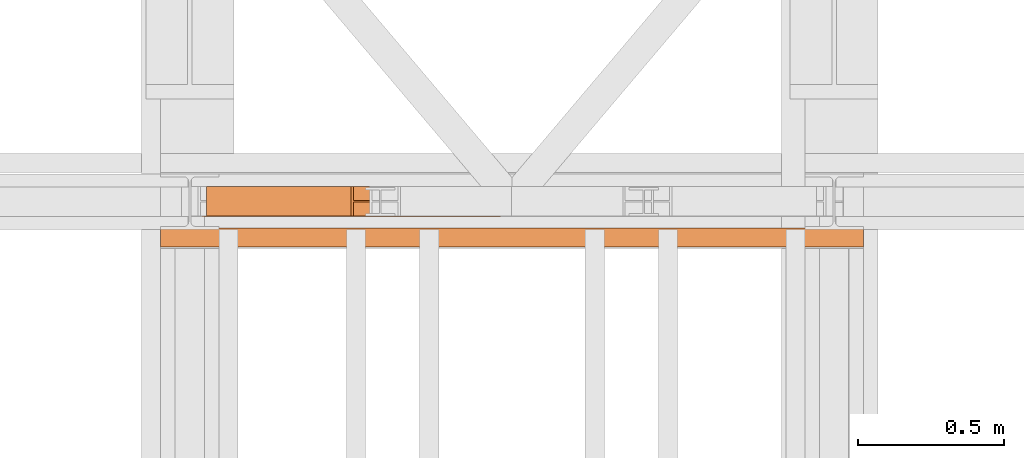
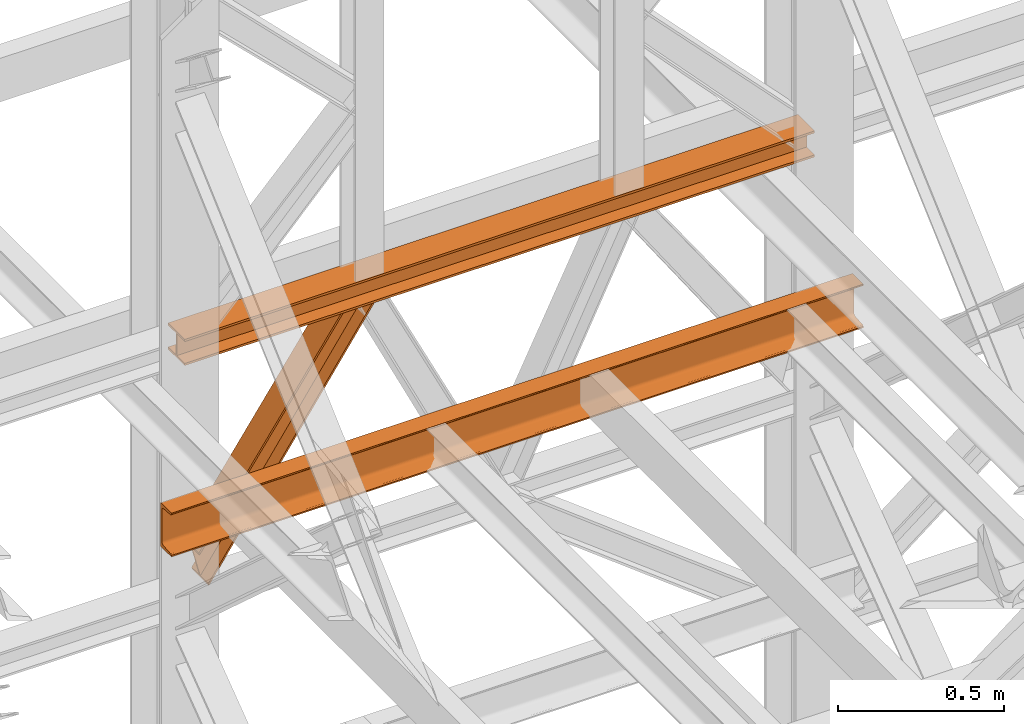
# One storey, part 163 of 208: 3 proxies.
"""IFC2X3 building model written with IfcOpenShell, lengths in millimetres."""

from ifc_helpers import new_model, entity, si_unit, converted_unit, frame, origin, origin_with_axes, place, context, subcontext, project, spatial, faceted_brep, element, save


model = new_model("IFC2X3")

# Units and contexts
model_context = context("Model", 3, precision=1e-05, world=origin())
plan_context = context("Plan", 3, precision=1e-05, world=origin())
body_context = subcontext(model_context, "Body", "Model", "MODEL_VIEW")
ifc_project = project(units=[si_unit("LENGTHUNIT", "METRE", prefix="MILLI"), converted_unit("PLANEANGLEUNIT", "DEGREE", entity("IfcPlaneAngleMeasure", 0.0174532925199433), si_unit("PLANEANGLEUNIT", "RADIAN"), dimensions=[0, 0, 0, 0, 0, 0, 0]), si_unit("AREAUNIT", "SQUARE_METRE"), si_unit("VOLUMEUNIT", "CUBIC_METRE")], contexts=[model_context, plan_context])

# Building, storey
building_placement = place(None, origin())
building = spatial("IfcBuilding", under=ifc_project, at=building_placement, CompositionType="COMPLEX")
storey_placement = place(building_placement, origin_with_axes())
storey = spatial("IfcBuildingStorey", under=building, at=storey_placement, Name="Geschoss", CompositionType="ELEMENT")

# Proxies
proxy_1_placement = place(storey_placement, frame((3350.592727804951, -13810.57439404318, 8872.310477686953), z_axis=(0.0, 0.0, 1.0), x_axis=(1.0, 0.0, 0.0)))
element("IfcBuildingElementProxy", 1, at=proxy_1_placement, inside=storey, context=body_context, shape_type="Brep", body=[
    faceted_brep([(2.129900098894723, 0.01000000000021828, 123.6259631817866), (0.01000000000021828, 0.01000000000021828, 131.7181462696044), (493.3676242930887, 0.01000000000021828, 837.8052355353921), (501.726157097236, 0.01000000000021828, 837.8052355353921), (0.01000000000021828, 0.01000000000021828, 131.7181462696044), (0.01000000000021828, 100.0100000000002, 131.7181462696044), (493.3676242930919, 100.0100000000002, 837.8052355353921), (493.3676242930887, 0.01000000000021828, 837.8052355353921), (0.01000000000021828, 100.0100000000002, 131.7181462696044), (2.129900098894723, 100.0100000000002, 123.6259631817866), (501.726157097236, 100.0100000000002, 837.8052355353921), (493.3676242930919, 100.0100000000002, 837.8052355353921), (2.129900098894723, 100.0100000000002, 123.6259631817866), (2.129900098894723, 52.51000000000022, 123.6259631817866), (501.7261570972382, 52.51000000000022, 837.8052355353921), (501.726157097236, 100.0100000000002, 837.8052355353921), (2.129900098894723, 52.51000000000022, 123.6259631817866), (32.3939208726315, 52.51000000000022, 8.100709325468415), (601.3553964383027, 52.51000000000022, 837.8052355353921), (501.7261570972382, 52.51000000000022, 837.8052355353921), (32.3939208726315, 52.51000000000022, 8.100709325468415), (32.39392087263059, 100.0100000000002, 8.100709325472053), (601.3553964382991, 100.0100000000002, 837.8052355353921), (601.3553964383027, 52.51000000000022, 837.8052355353921), (32.39392087263059, 100.0100000000002, 8.100709325472053), (34.51343489165902, 100.0100000000002, 0.01000000000021828), (609.6918638003699, 100.0100000000002, 837.8052355353921), (601.3553964382991, 100.0100000000002, 837.8052355353921), (34.51343489165902, 100.0100000000002, 0.01000000000021828), (34.51343489165993, 0.01000000000021828, 0.01000000000021828), (609.6918638003713, 0.01000000000021828, 837.8052355353921), (609.6918638003699, 100.0100000000002, 837.8052355353921), (34.51343489165993, 0.01000000000021828, 0.01000000000021828), (32.39392087263059, 0.01000000000021828, 8.100709325472053), (601.3553964382968, 0.01000000000021828, 837.8052355353921), (609.6918638003713, 0.01000000000021828, 837.8052355353921), (32.39392087263059, 0.01000000000021828, 8.100709325472053), (32.39392087262968, 47.51000000000022, 8.100709325475691), (601.3553964382982, 47.51000000000022, 837.8052355353884), (601.3553964382968, 0.01000000000021828, 837.8052355353921), (32.39392087262968, 47.51000000000022, 8.100709325475691), (2.129900098894723, 47.51000000000022, 123.6259631817866), (501.726157097236, 47.51000000000022, 837.8052355353921), (601.3553964382982, 47.51000000000022, 837.8052355353884), (2.129900098894723, 47.51000000000022, 123.6259631817866), (2.129900098894723, 0.01000000000021828, 123.6259631817866), (501.726157097236, 0.01000000000021828, 837.8052355353921), (501.726157097236, 47.51000000000022, 837.8052355353921), (0.01000000000021828, 0.01000000000021828, 131.7181462696044), (2.129900098894723, 0.01000000000021828, 123.6259631817866), (2.129900098894723, 47.51000000000022, 123.6259631817866), (32.39392087262968, 47.51000000000022, 8.100709325475691), (32.39392087263059, 0.01000000000021828, 8.100709325472053), (34.51343489165993, 0.01000000000021828, 0.01000000000021828), (34.51343489165902, 100.0100000000002, 0.01000000000021828), (32.39392087263059, 100.0100000000002, 8.100709325472053), (32.3939208726315, 52.51000000000022, 8.100709325468415), (2.129900098894723, 52.51000000000022, 123.6259631817866), (2.129900098894723, 100.0100000000002, 123.6259631817866), (0.01000000000021828, 100.0100000000002, 131.7181462696044), (501.726157097236, 0.01000000000021828, 837.8052355353921), (493.3676242930887, 0.01000000000021828, 837.8052355353921), (493.3676242930919, 100.0100000000002, 837.8052355353921), (501.726157097236, 100.0100000000002, 837.8052355353921), (501.7261570972382, 52.51000000000022, 837.8052355353921), (601.3553964383027, 52.51000000000022, 837.8052355353921), (601.3553964382991, 100.0100000000002, 837.8052355353921), (609.6918638003699, 100.0100000000002, 837.8052355353921), (609.6918638003713, 0.01000000000021828, 837.8052355353921), (601.3553964382968, 0.01000000000021828, 837.8052355353921), (601.3553964382982, 47.51000000000022, 837.8052355353884), (501.726157097236, 47.51000000000022, 837.8052355353921)], [[[0, 1, 2, 3]], [[4, 5, 6, 7]], [[8, 9, 10, 11]], [[12, 13, 14, 15]], [[16, 17, 18, 19]], [[20, 21, 22, 23]], [[24, 25, 26, 27]], [[28, 29, 30, 31]], [[32, 33, 34, 35]], [[36, 37, 38, 39]], [[40, 41, 42, 43]], [[44, 45, 46, 47]], [[48, 49, 50, 51, 52, 53, 54, 55, 56, 57, 58, 59]], [[60, 61, 62, 63, 64, 65, 66, 67, 68, 69, 70, 71]]], orient=[[False], [False], [False], [False], [False], [False], [False], [False], [False], [False], [False], [False], [False], [False]]),
])
proxy_2_placement = place(storey_placement, frame((3300.078579848443, -13812.57439031789, 9710.105713222343), z_axis=(0.0, 0.0, 1.0), x_axis=(1.0, 0.0, 0.0)))
element("IfcBuildingElementProxy", 2, at=proxy_2_placement, inside=storey, context=body_context, shape_type="Brep", body=[
    faceted_brep([(2184.825809875727, 0.01000000000021828, 8.010000000000218), (2184.825809875727, 47.51000000000022, 8.010000000000218), (2184.825809875727, 47.51000000000022, 88.01000000000204), (2184.825809875727, 0.01000000000021828, 88.01000000000204), (2184.825809875727, 0.01000000000021828, 96.01000000000022), (2184.825809875727, 100.0100000000002, 96.01000000000022), (2184.825809875727, 100.0100000000002, 88.01000000000204), (2184.825809875727, 52.51000000000022, 88.01000000000204), (2184.825809875727, 52.51000000000022, 8.010000000000218), (2184.825809875727, 100.0100000000002, 8.010000000000218), (2184.825809875727, 100.0100000000002, 0.01000000000021828), (2184.825809875727, 0.01000000000021828, 0.01000000000021828), (2184.825809875727, 0.01000000000021828, 0.01000000000021828), (0.01000000000021828, 0.01000000000385626, 0.01000000000203727), (0.01000000000021828, 0.01000000000385626, 8.010000000000218), (2184.825809875727, 0.01000000000021828, 8.010000000000218), (2184.825809875727, 100.0100000000002, 0.01000000000021828), (0.01000000000021828, 100.0100000000039, 0.01000000000021828), (0.01000000000021828, 0.01000000000385626, 0.01000000000203727), (2184.825809875727, 0.01000000000021828, 0.01000000000021828), (2184.825809875727, 100.0100000000002, 8.010000000000218), (0.01000000000021828, 100.0100000000039, 8.010000000000218), (0.01000000000021828, 100.0100000000039, 0.01000000000021828), (2184.825809875727, 100.0100000000002, 0.01000000000021828), (2184.825809875727, 52.51000000000022, 8.010000000000218), (0.01000000000021828, 52.51000000000386, 8.010000000000218), (0.01000000000021828, 100.0100000000039, 8.010000000000218), (2184.825809875727, 100.0100000000002, 8.010000000000218), (2184.825809875727, 52.51000000000022, 88.01000000000204), (0.01000000000021828, 52.51000000000386, 88.01000000000204), (0.01000000000021828, 52.51000000000386, 8.010000000000218), (2184.825809875727, 52.51000000000022, 8.010000000000218), (2184.825809875727, 100.0100000000002, 88.01000000000204), (0.01000000000021828, 100.0100000000039, 88.01000000000204), (0.01000000000021828, 52.51000000000386, 88.01000000000204), (2184.825809875727, 52.51000000000022, 88.01000000000204), (2184.825809875727, 100.0100000000002, 96.01000000000022), (0.01000000000021828, 100.0100000000039, 96.01000000000022), (0.01000000000021828, 100.0100000000039, 88.01000000000204), (2184.825809875727, 100.0100000000002, 88.01000000000204), (2184.825809875727, 0.01000000000021828, 96.01000000000022), (0.01000000000021828, 0.01000000000385626, 96.01000000000022), (0.01000000000021828, 100.0100000000039, 96.01000000000022), (2184.825809875727, 100.0100000000002, 96.01000000000022), (2184.825809875727, 0.01000000000021828, 88.01000000000204), (0.01000000000021828, 0.01000000000385626, 88.01000000000022), (0.01000000000021828, 0.01000000000385626, 96.01000000000022), (2184.825809875727, 0.01000000000021828, 96.01000000000022), (2184.825809875727, 47.51000000000022, 88.01000000000204), (0.01000000000021828, 47.51000000000386, 88.01000000000204), (0.01000000000021828, 0.01000000000385626, 88.01000000000022), (2184.825809875727, 0.01000000000021828, 88.01000000000204), (2184.825809875727, 47.51000000000022, 8.010000000000218), (0.01000000000021828, 47.51000000000386, 8.010000000000218), (0.01000000000021828, 47.51000000000386, 88.01000000000204), (2184.825809875727, 47.51000000000022, 88.01000000000204), (2184.825809875727, 0.01000000000021828, 8.010000000000218), (0.01000000000021828, 0.01000000000385626, 8.010000000000218), (0.01000000000021828, 47.51000000000386, 8.010000000000218), (2184.825809875727, 47.51000000000022, 8.010000000000218), (0.01000000000021828, 0.01000000000385626, 8.010000000000218), (0.01000000000021828, 0.01000000000385626, 0.01000000000203727), (0.01000000000021828, 100.0100000000039, 0.01000000000021828), (0.01000000000021828, 100.0100000000039, 8.010000000000218), (0.01000000000021828, 52.51000000000386, 8.010000000000218), (0.01000000000021828, 52.51000000000386, 88.01000000000204), (0.01000000000021828, 100.0100000000039, 88.01000000000204), (0.01000000000021828, 100.0100000000039, 96.01000000000022), (0.01000000000021828, 0.01000000000385626, 96.01000000000022), (0.01000000000021828, 0.01000000000385626, 88.01000000000022), (0.01000000000021828, 47.51000000000386, 88.01000000000204), (0.01000000000021828, 47.51000000000386, 8.010000000000218)], [[[0, 1, 2, 3, 4, 5, 6, 7, 8, 9, 10, 11]], [[12, 13, 14, 15]], [[16, 17, 18, 19]], [[20, 21, 22, 23]], [[24, 25, 26, 27]], [[28, 29, 30, 31]], [[32, 33, 34, 35]], [[36, 37, 38, 39]], [[40, 41, 42, 43]], [[44, 45, 46, 47]], [[48, 49, 50, 51]], [[52, 53, 54, 55]], [[56, 57, 58, 59]], [[60, 61, 62, 63, 64, 65, 66, 67, 68, 69, 70, 71]]], orient=[[False], [False], [False], [False], [False], [False], [False], [False], [False], [False], [False], [False], [False], [False]]),
])
proxy_3_placement = place(storey_placement, frame((3193.302372304859, -13917.58293324866, 9109.989999999998), z_axis=(0.0, 0.0, 1.0), x_axis=(1.0, 0.0, 0.0)))
element("IfcBuildingElementProxy", 3, at=proxy_3_placement, inside=storey, context=body_context, shape_type="Brep", body=[
    faceted_brep([(2399.962597713924, 65.01000000000022, 160.0100000000002), (2399.962597713924, 0.01000000000021828, 160.0100000000002), (0.009999999999763531, 0.01853275732901238, 160.0100000000002), (0.009999999999763531, 65.01853275732901, 160.0100000000002), (2399.962597713924, 0.01000000000021828, 160.0100000000002), (2399.962597713924, 0.01000000000021828, 156.8875719297539), (0.009999999999763531, 0.01853275732901238, 156.8875719297539), (0.009999999999763531, 0.01853275732901238, 160.0100000000002), (2399.962597713924, 0.01000000000021828, 156.8875719297539), (2399.962597713924, 0.2527365771729819, 155.2717110918293), (0.009999999999763531, 0.261269334501776, 155.2717110918293), (0.009999999999763531, 0.01853275732901238, 156.8875719297539), (2399.962597713924, 0.2527365771729819, 155.2717110918293), (2399.962597713924, 0.959467714144921, 153.7984655565542), (0.009999999999763531, 0.9680004714700772, 153.7984655565542), (0.009999999999763531, 0.261269334501776, 155.2717110918293), (2399.962597713924, 0.959467714144921, 153.7984655565542), (2399.962597713924, 2.067848361532015, 152.5978732961266), (0.009999999999763531, 2.076381118860809, 152.5978732961266), (0.009999999999763531, 0.9680004714700772, 153.7984655565542), (2399.962597713924, 2.067848361532015, 152.5978732961266), (2399.962597713924, 3.480043588517219, 151.7759086082897), (0.009999999999763531, 3.488576345846013, 151.7759086082897), (0.009999999999763531, 2.076381118860809, 152.5978732961266), (2399.962597713924, 3.480043588517219, 151.7759086082897), (2399.962597713924, 5.071401277446057, 151.4050878978051), (0.009999999999763531, 5.079934034774851, 151.4050878978051), (0.009999999999763531, 3.488576345846013, 151.7759086082897), (2399.962597713924, 5.071401277446057, 151.4050878978051), (2399.962597713924, 47.84732483397056, 147.9830140132835), (0.009999999999763531, 47.85585759129936, 147.9830140132835), (0.009999999999763531, 5.079934034774851, 151.4050878978051), (2399.962597713924, 47.84732483397056, 147.9830140132835), (2399.962597713924, 50.8115917919913, 147.318026761528), (0.009999999999763531, 50.8201245493201, 147.318026761528), (0.009999999999763531, 47.85585759129936, 147.9830140132835), (2399.962597713924, 50.8115917919913, 147.318026761528), (2399.962597713924, 53.5813804007139, 145.7058782528511), (0.009999999999763531, 53.58991315803905, 145.7058782528511), (0.009999999999763531, 50.8201245493201, 147.318026761528), (2399.962597713924, 53.5813804007139, 145.7058782528511), (2399.962597713924, 55.69737981845356, 143.4138384829421), (0.009999999999763531, 55.70591257578235, 143.4138384829421), (0.009999999999763531, 53.58991315803905, 145.7058782528511), (2399.962597713924, 55.69737981845356, 143.4138384829421), (2399.962597713924, 57.04659380721387, 140.6012788246917), (0.009999999999763531, 57.05512656454266, 140.6012788246917), (0.009999999999763531, 55.70591257578235, 143.4138384829421), (2399.962597713924, 57.04659380721387, 140.6012788246917), (2399.962597713924, 57.51000000000022, 137.5164535886543), (0.009999999999763531, 57.51853275732901, 137.5164535886543), (0.009999999999763531, 57.05512656454266, 140.6012788246917), (2399.962597713924, 57.51000000000022, 137.5164535886543), (2399.962597713924, 57.51000000000022, 22.503546411348), (0.009999999999763531, 57.51853275732901, 22.503546411348), (0.009999999999763531, 57.51853275732901, 137.5164535886543), (2399.962597713924, 57.51000000000022, 22.503546411348), (2399.962597713924, 57.04659380721387, 19.41872117530875), (0.009999999999763531, 57.05512656454266, 19.41872117530875), (0.009999999999763531, 57.51853275732901, 22.503546411348), (2399.962597713924, 57.04659380721387, 19.41872117530875), (2399.962597713924, 55.69737981845356, 16.60616151705835), (0.009999999999763531, 55.70591257578235, 16.60616151705835), (0.009999999999763531, 57.05512656454266, 19.41872117530875), (2399.962597713924, 55.69737981845356, 16.60616151705835), (2399.962597713924, 53.5813804007139, 14.31412174714933), (0.009999999999763531, 53.58991315803905, 14.31412174714933), (0.009999999999763531, 55.70591257578235, 16.60616151705835), (2399.962597713924, 53.5813804007139, 14.31412174714933), (2399.962597713924, 50.88537133101818, 12.74491643400688), (0.009999999999763531, 50.89390408834333, 12.74491643400688), (0.009999999999763531, 53.58991315803905, 14.31412174714933), (2399.962597713924, 50.88537133101818, 12.74491643400688), (2399.962597713924, 47.84732483397056, 12.03698598671872), (0.009999999999763531, 47.85585759129936, 12.03698598671872), (0.009999999999763531, 50.89390408834333, 12.74491643400688), (2399.962597713924, 47.84732483397056, 12.03698598671872), (2399.962597713924, 5.071401277446057, 8.614912102195376), (0.009999999999763531, 5.079934034774851, 8.614912102195376), (0.009999999999763531, 47.85585759129936, 12.03698598671872), (2399.962597713924, 5.071401277446057, 8.614912102195376), (2399.962597713924, 3.480043588517219, 8.244091391710754), (0.009999999999763531, 3.488576345846013, 8.244091391710754), (0.009999999999763531, 5.079934034774851, 8.614912102195376), (2399.962597713924, 3.480043588517219, 8.244091391710754), (2399.962597713924, 2.067848361532015, 7.422126703873801), (0.009999999999763531, 2.076381118860809, 7.422126703873801), (0.009999999999763531, 3.488576345846013, 8.244091391710754), (2399.962597713924, 2.067848361532015, 7.422126703873801), (2399.962597713924, 0.959467714144921, 6.221534443446217), (0.009999999999763531, 0.9680004714700772, 6.221534443446217), (0.009999999999763531, 2.076381118860809, 7.422126703873801), (2399.962597713924, 0.959467714144921, 6.221534443446217), (2399.962597713924, 0.2527365771729819, 4.748288908172981), (0.009999999999763531, 0.261269334501776, 4.748288908172981), (0.009999999999763531, 0.9680004714700772, 6.221534443446217), (2399.962597713924, 0.2527365771729819, 4.748288908172981), (2399.962597713924, 0.01000000000021828, 0.01000000000021828), (0.009999999999763531, 0.01853275732901238, 0.01000000000021828), (0.009999999999763531, 0.261269334501776, 4.748288908172981), (2399.962597713924, 0.01000000000021828, 0.01000000000021828), (2399.962597713924, 65.01000000000022, 0.01000000000021828), (0.009999999999763531, 65.01853275732901, 0.01000000000021828), (0.009999999999763531, 0.01853275732901238, 0.01000000000021828), (2399.962597713924, 65.01000000000022, 0.01000000000021828), (2399.962597713924, 65.01000000000022, 160.0100000000002), (0.009999999999763531, 65.01853275732901, 160.0100000000002), (0.009999999999763531, 65.01853275732901, 0.01000000000021828), (2399.962597713924, 65.01000000000022, 160.0100000000002), (2399.962597713924, 65.01000000000022, 0.01000000000021828), (2399.962597713924, 0.01000000000021828, 0.01000000000021828), (2399.962597713924, 0.2527365771729819, 4.748288908172981), (2399.962597713924, 0.959467714144921, 6.221534443446217), (2399.962597713924, 2.067848361532015, 7.422126703873801), (2399.962597713924, 3.480043588517219, 8.244091391710754), (2399.962597713924, 5.071401277446057, 8.614912102195376), (2399.962597713924, 47.84732483397056, 12.03698598671872), (2399.962597713924, 50.88537133101818, 12.74491643400688), (2399.962597713924, 53.5813804007139, 14.31412174714933), (2399.962597713924, 55.69737981845356, 16.60616151705835), (2399.962597713924, 57.04659380721387, 19.41872117530875), (2399.962597713924, 57.51000000000022, 22.503546411348), (2399.962597713924, 57.51000000000022, 137.5164535886543), (2399.962597713924, 57.04659380721387, 140.6012788246917), (2399.962597713924, 55.69737981845356, 143.4138384829421), (2399.962597713924, 53.5813804007139, 145.7058782528511), (2399.962597713924, 50.8115917919913, 147.318026761528), (2399.962597713924, 47.84732483397056, 147.9830140132835), (2399.962597713924, 5.071401277446057, 151.4050878978051), (2399.962597713924, 3.480043588517219, 151.7759086082897), (2399.962597713924, 2.067848361532015, 152.5978732961266), (2399.962597713924, 0.959467714144921, 153.7984655565542), (2399.962597713924, 0.2527365771729819, 155.2717110918293), (2399.962597713924, 0.01000000000021828, 156.8875719297539), (2399.962597713924, 0.01000000000021828, 160.0100000000002), (0.009999999999763531, 65.01853275732901, 160.0100000000002), (0.009999999999763531, 0.01853275732901238, 160.0100000000002), (0.009999999999763531, 0.01853275732901238, 156.8875719297539), (0.009999999999763531, 0.261269334501776, 155.2717110918293), (0.009999999999763531, 0.9680004714700772, 153.7984655565542), (0.009999999999763531, 2.076381118860809, 152.5978732961266), (0.009999999999763531, 3.488576345846013, 151.7759086082897), (0.009999999999763531, 5.079934034774851, 151.4050878978051), (0.009999999999763531, 47.85585759129936, 147.9830140132835), (0.009999999999763531, 50.8201245493201, 147.318026761528), (0.009999999999763531, 53.58991315803905, 145.7058782528511), (0.009999999999763531, 55.70591257578235, 143.4138384829421), (0.009999999999763531, 57.05512656454266, 140.6012788246917), (0.009999999999763531, 57.51853275732901, 137.5164535886543), (0.009999999999763531, 57.51853275732901, 22.503546411348), (0.009999999999763531, 57.05512656454266, 19.41872117530875), (0.009999999999763531, 55.70591257578235, 16.60616151705835), (0.009999999999763531, 53.58991315803905, 14.31412174714933), (0.009999999999763531, 50.89390408834333, 12.74491643400688), (0.009999999999763531, 47.85585759129936, 12.03698598671872), (0.009999999999763531, 5.079934034774851, 8.614912102195376), (0.009999999999763531, 3.488576345846013, 8.244091391710754), (0.009999999999763531, 2.076381118860809, 7.422126703873801), (0.009999999999763531, 0.9680004714700772, 6.221534443446217), (0.009999999999763531, 0.261269334501776, 4.748288908172981), (0.009999999999763531, 0.01853275732901238, 0.01000000000021828), (0.009999999999763531, 65.01853275732901, 0.01000000000021828)], [[[0, 1, 2, 3]], [[4, 5, 6, 7]], [[8, 9, 10, 11]], [[12, 13, 14, 15]], [[16, 17, 18, 19]], [[20, 21, 22, 23]], [[24, 25, 26, 27]], [[28, 29, 30, 31]], [[32, 33, 34, 35]], [[36, 37, 38, 39]], [[40, 41, 42, 43]], [[44, 45, 46, 47]], [[48, 49, 50, 51]], [[52, 53, 54, 55]], [[56, 57, 58, 59]], [[60, 61, 62, 63]], [[64, 65, 66, 67]], [[68, 69, 70, 71]], [[72, 73, 74, 75]], [[76, 77, 78, 79]], [[80, 81, 82, 83]], [[84, 85, 86, 87]], [[88, 89, 90, 91]], [[92, 93, 94, 95]], [[96, 97, 98, 99]], [[100, 101, 102, 103]], [[104, 105, 106, 107]], [[108, 109, 110, 111, 112, 113, 114, 115, 116, 117, 118, 119, 120, 121, 122, 123, 124, 125, 126, 127, 128, 129, 130, 131, 132, 133, 134]], [[135, 136, 137, 138, 139, 140, 141, 142, 143, 144, 145, 146, 147, 148, 149, 150, 151, 152, 153, 154, 155, 156, 157, 158, 159, 160, 161]]], orient=[[False], [False], [False], [False], [False], [False], [False], [False], [False], [False], [False], [False], [False], [False], [False], [False], [False], [False], [False], [False], [False], [False], [False], [False], [False], [False], [False], [False], [False]]),
])

save(model, "model.ifc")
